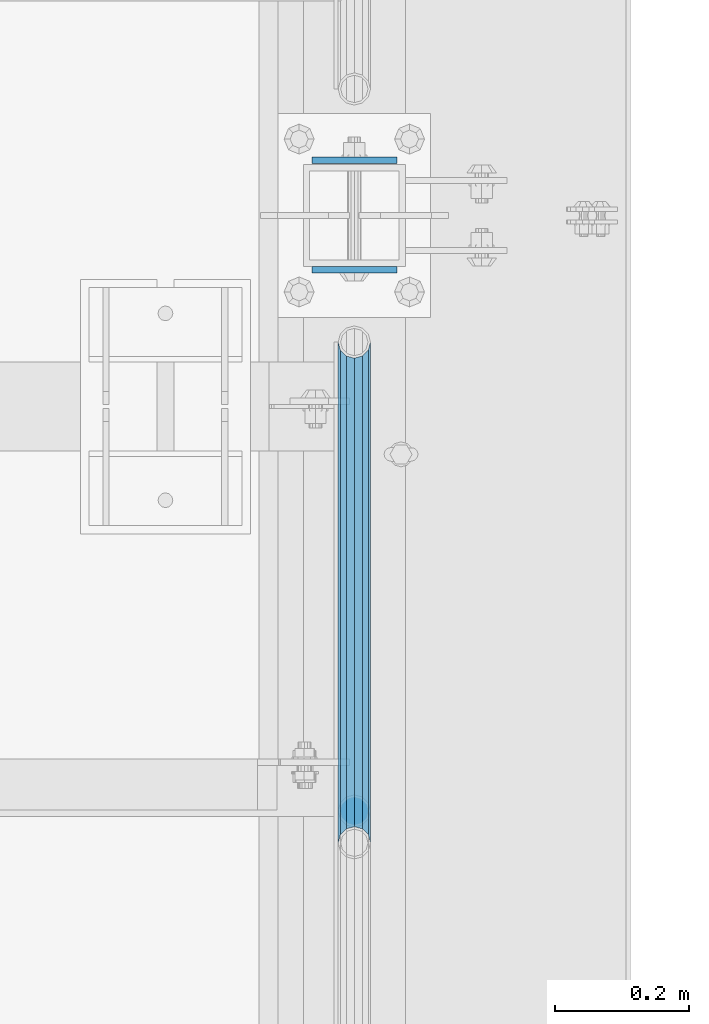
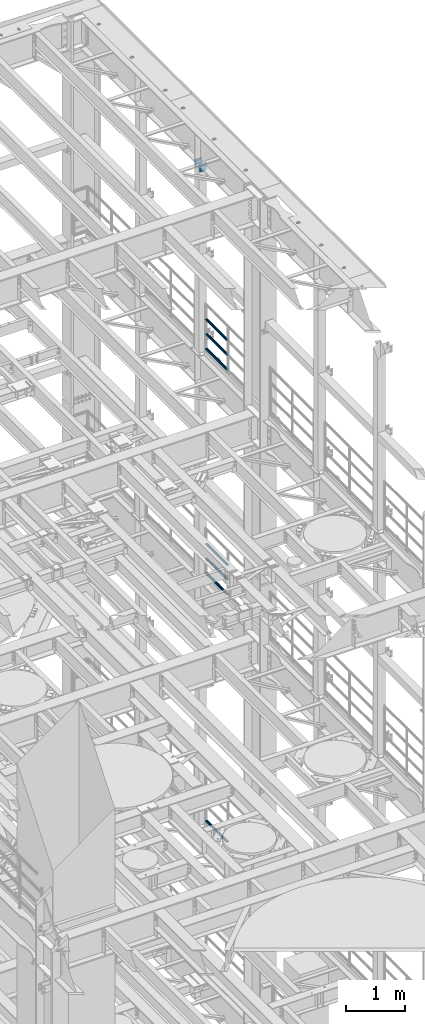
# One storey, part 1343 of 1876: 9 beams, 4 elements without a shape of their own.
"""IFC2X3 building model written with IfcOpenShell, lengths in millimetres."""

from ifc_helpers import new_model, si_unit, frame, origin_with_axes, place, context, subcontext, project, spatial, faceted_brep, material, type_object, element, aggregate, save


model = new_model("IFC2X3")

# Units and contexts
model_context = context("Model", 3, precision=1e-05, world=origin_with_axes())
body_context = subcontext(model_context, "Body", "Model", "MODEL_VIEW")
ifc_project = project(units=[si_unit("LENGTHUNIT", "METRE", prefix="MILLI"), si_unit("AREAUNIT", "SQUARE_METRE"), si_unit("VOLUMEUNIT", "CUBIC_METRE"), si_unit("MASSUNIT", "GRAM", prefix="KILO"), si_unit("TIMEUNIT", "SECOND"), si_unit("PLANEANGLEUNIT", "RADIAN"), si_unit("SOLIDANGLEUNIT", "STERADIAN"), si_unit("THERMODYNAMICTEMPERATUREUNIT", "DEGREE_CELSIUS"), si_unit("LUMINOUSINTENSITYUNIT", "LUMEN")], contexts=[model_context])

# Site, building, storey
site_placement = place(None, origin_with_axes())
site = spatial("IfcSite", under=ifc_project, at=site_placement, CompositionType="ELEMENT")
building_placement = place(site_placement, origin_with_axes())
building = spatial("IfcBuilding", under=site, at=building_placement, Name="Undefined", CompositionType="ELEMENT")
storey_placement = place(building_placement, origin_with_axes())
storey = spatial("IfcBuildingStorey", under=building, at=storey_placement, Name="Undefined", CompositionType="ELEMENT", Elevation=0.0)

# Assembly, beams
assembly_1_placement = place(storey_placement, origin_with_axes())
assembly_1 = element("IfcElementAssembly", 1, at=assembly_1_placement, inside=storey, Name="RAIL", AssemblyPlace="NOTDEFINED", PredefinedType="RIGID_FRAME")
ifc_material_1 = material()
beam_type_1 = type_object("IfcBeamType", Name="PIPE1-1/2SCH40", PredefinedType="NOTDEFINED")
beam_1_placement = place(assembly_1_placement, frame((7620.0, 9462.77, 18145.125), z_axis=(0.0, 0.0, 1.0), x_axis=(0.0, -1.0, 0.0)))
beam_1 = element("IfcBeam", 2, at=beam_1_placement, type_object=beam_type_1, material=ifc_material_1, Name="RAIL", ObjectType="PIPE1-1/2SCH40", context=body_context, shape_type="Brep", body=[
    faceted_brep([(728.085307006683, -12.0649999999996, 20.8971929933177), (728.085307006683, -12.0649999999996, 15.8661214311796), (727.591878568821, -10.2235000000001, 17.7076214311819), (724.852500000002, 0.0, 20.4470000000001), (724.852500000002, 0.0, 24.130000000001), (727.591878568821, 10.2235000000001, 17.7076214311819), (728.085307006683, 12.0649999999996, 15.8661214311796), (728.085307006683, 12.0649999999996, 20.8971929933177), (748.982500000002, 24.1300000000001, 0.0), (736.917500000002, 20.8971929933186, 12.0649999999987), (736.917500000002, 20.8971929933186, -12.0649999999987), (733.727928437864, 17.7076214311801, 10.2235000000001), (736.467307006683, 20.4470000000001, 0.0), (733.727928437864, 17.7076214311801, -10.2235000000001), (728.085307006683, 12.0649999999996, -15.8661214311796), (728.085307006683, 12.0649999999996, -20.8971929933177), (727.591878568821, 10.2235000000001, -17.7076214311819), (724.852500000002, 0.0, -20.4470000000001), (724.852500000002, 0.0, -24.130000000001), (728.085307006683, -12.0649999999996, -15.8661214311796), (728.085307006683, -12.0649999999996, -20.8971929933177), (727.591878568821, -10.2235000000001, -17.7076214311819), (748.982500000002, -24.1300000000001, 0.0), (736.917500000002, -20.8971929933186, -12.0649999999987), (736.917500000002, -20.8971929933186, 12.0649999999987), (733.727928437864, -17.7076214311801, -10.2235000000001), (736.467307006683, -20.4470000000001, 0.0), (733.727928437864, -17.7076214311801, 10.2235000000001), (12.0650000000064, -20.8971929933177, -12.0649999999987), (20.8971929933249, -12.0650000000005, -20.8971929933177), (0.0, 24.1299999999992, 0.0), (12.0650000000064, 20.8971929933177, -12.0649999999987), (12.0650000000064, 20.8971929933177, 12.0649999999987), (20.8971929933249, 12.0650000000005, 20.8971929933177), (24.1300000000064, 0.0, 24.130000000001), (20.8971929933249, 12.0650000000005, -20.8971929933177), (24.1300000000063, 0.0, -24.130000000001), (24.1300000000063, 0.0, -20.4470000000001), (20.8971929933249, -12.0650000000005, -15.8661214311796), (21.3906214311868, -10.2235000000001, -17.7076214311819), (21.3906214311868, 10.2235000000001, -17.7076214311819), (20.8971929933249, 12.0650000000005, -15.8661214311796), (15.2545715621445, 17.7076214311801, -10.2235000000001), (12.5151929933249, 20.4470000000001, 0.0), (15.2545715621445, 17.7076214311801, 10.2235000000001), (20.8971929933249, 12.0650000000005, 15.8661214311796), (21.3906214311868, 10.2235000000001, 17.7076214311819), (24.1300000000064, 0.0, 20.4470000000001), (21.3906214311868, -10.2235000000001, 17.7076214311819), (20.8971929933249, -12.0650000000005, 15.8661214311796), (20.8971929933249, -12.0650000000005, 20.8971929933177), (12.0650000000064, -20.8971929933177, 12.0649999999987), (0.0, -24.1299999999992, 0.0), (15.2545715621445, -17.7076214311801, 10.2235000000001), (12.5151929933249, -20.4470000000001, 0.0), (15.2545715621445, -17.7076214311801, -10.2235000000001)], [[[0, 1, 2, 3, 4]], [[4, 3, 5, 6, 7]], [[8, 9, 10]], [[7, 6, 11, 12, 13, 14, 15, 10, 9]], [[16, 17, 18, 15, 14]], [[19, 20, 18, 17, 21]], [[22, 23, 24]], [[24, 23, 20, 19, 25, 26, 27, 1, 0]], [[28, 29, 20, 23]], [[30, 31, 32]], [[33, 34, 4, 7]], [[32, 33, 7, 9]], [[30, 32, 9, 8]], [[31, 30, 8, 10]], [[35, 31, 10, 15]], [[36, 35, 15, 18]], [[29, 36, 18, 20]], [[37, 36, 29, 38, 39]], [[40, 41, 35, 36, 37]], [[32, 31, 35, 41, 42, 43, 44, 45, 33]], [[33, 45, 46, 47, 34]], [[34, 47, 48, 49, 50]], [[34, 50, 0, 4]], [[50, 51, 24, 0]], [[51, 52, 22, 24]], [[52, 28, 23, 22]], [[51, 28, 52]], [[50, 49, 53, 54, 55, 38, 29, 28, 51]], [[55, 54, 26, 25]], [[21, 39, 38, 55, 25, 19]], [[37, 39, 21, 17]], [[40, 37, 17, 16]], [[42, 41, 40, 16, 14, 13]], [[43, 42, 13, 12]], [[44, 43, 12, 11]], [[5, 46, 45, 44, 11, 6]], [[47, 46, 5, 3]], [[48, 47, 3, 2]], [[53, 49, 48, 2, 1, 27]], [[54, 53, 27, 26]]]),
])
beam_2_placement = place(assembly_1_placement, frame((7620.0, 8713.7875, 18449.925), z_axis=(0.0, 0.0, -1.0), x_axis=(0.0, 1.0, 0.0)))
beam_2 = element("IfcBeam", 3, at=beam_2_placement, type_object=beam_type_1, material=ifc_material_1, Name="RAIL", ObjectType="PIPE1-1/2SCH40", context=body_context, shape_type="Brep", body=[
    faceted_brep([(0.0, 24.1299999999992, 0.0), (12.0650000000064, 20.8971929933177, -12.0649999999987), (12.0650000000064, 20.8971929933177, 12.0649999999987), (12.0650000000064, -20.8971929933177, 12.0649999999987), (12.0650000000064, -20.8971929933177, -12.0649999999987), (0.0, -24.1299999999992, 0.0), (20.8971929933249, -12.0650000000005, 20.8971929933177), (20.8971929933249, -12.0650000000005, 15.8661214311796), (15.2545715621445, -17.7076214311801, 10.2235000000001), (12.5151929933249, -20.4470000000001, 0.0), (15.2545715621445, -17.7076214311801, -10.2235000000001), (20.8971929933249, -12.0650000000005, -15.8661214311796), (20.8971929933249, -12.0650000000005, -20.8971929933177), (24.1300000000063, 0.0, -20.4470000000001), (24.1300000000063, 0.0, -24.130000000001), (21.3906214311868, -10.2235000000001, -17.7076214311819), (21.3906214311868, 10.2235000000001, -17.7076214311819), (20.8971929933249, 12.0650000000005, -15.8661214311796), (20.8971929933249, 12.0650000000005, -20.8971929933177), (15.2545715621445, 17.7076214311801, -10.2235000000001), (12.5151929933249, 20.4470000000001, 0.0), (15.2545715621445, 17.7076214311801, 10.2235000000001), (20.8971929933249, 12.0650000000005, 15.8661214311796), (20.8971929933249, 12.0650000000005, 20.8971929933177), (21.3906214311868, 10.2235000000001, 17.7076214311819), (24.1300000000064, 0.0, 20.4470000000001), (24.1300000000064, 0.0, 24.130000000001), (21.3906214311868, -10.2235000000001, 17.7076214311819), (748.982500000002, 24.1300000000001, 0.0), (736.917500000002, 20.8971929933186, -12.0649999999987), (728.085307006683, 12.0649999999996, -20.8971929933177), (748.982500000002, -24.1300000000001, 0.0), (736.917500000002, -20.8971929933186, -12.0649999999987), (736.917500000002, -20.8971929933186, 12.0649999999987), (728.085307006683, -12.0649999999996, 20.8971929933177), (728.085307006683, -12.0649999999996, -20.8971929933177), (724.852500000002, 0.0, -24.130000000001), (727.591878568821, 10.2235000000001, -17.7076214311819), (724.852500000002, 0.0, -20.4470000000001), (728.085307006683, 12.0649999999996, -15.8661214311796), (728.085307006683, -12.0649999999996, -15.8661214311796), (727.591878568821, -10.2235000000001, -17.7076214311819), (733.727928437864, -17.7076214311801, -10.2235000000001), (736.467307006683, -20.4470000000001, 0.0), (733.727928437864, -17.7076214311801, 10.2235000000001), (728.085307006683, -12.0649999999996, 15.8661214311796), (727.591878568821, -10.2235000000001, 17.7076214311819), (724.852500000002, 0.0, 20.4470000000001), (724.852500000002, 0.0, 24.130000000001), (728.085307006683, 12.0649999999996, 20.8971929933177), (736.917500000002, 20.8971929933186, 12.0649999999987), (728.085307006683, 12.0649999999996, 15.8661214311796), (733.727928437864, 17.7076214311801, 10.2235000000001), (736.467307006683, 20.4470000000001, 0.0), (733.727928437864, 17.7076214311801, -10.2235000000001), (727.591878568821, 10.2235000000001, 17.7076214311819)], [[[0, 1, 2]], [[3, 4, 5]], [[6, 7, 8, 9, 10, 11, 12, 4, 3]], [[13, 14, 12, 11, 15]], [[16, 17, 18, 14, 13]], [[2, 1, 18, 17, 19, 20, 21, 22, 23]], [[23, 22, 24, 25, 26]], [[26, 25, 27, 7, 6]], [[1, 0, 28, 29]], [[18, 1, 29, 30]], [[31, 32, 33]], [[6, 3, 33, 34]], [[3, 5, 31, 33]], [[5, 4, 32, 31]], [[4, 12, 35, 32]], [[12, 14, 36, 35]], [[14, 18, 30, 36]], [[37, 38, 36, 30, 39]], [[40, 35, 36, 38, 41]], [[33, 32, 35, 40, 42, 43, 44, 45, 34]], [[34, 45, 46, 47, 48]], [[26, 6, 34, 48]], [[2, 23, 49, 50]], [[23, 26, 48, 49]], [[0, 2, 50, 28]], [[28, 50, 29]], [[49, 51, 52, 53, 54, 39, 30, 29, 50]], [[48, 47, 55, 51, 49]], [[25, 24, 55, 47]], [[55, 24, 22, 21, 52, 51]], [[21, 20, 53, 52]], [[20, 19, 54, 53]], [[19, 17, 16, 37, 39, 54]], [[16, 13, 38, 37]], [[13, 15, 41, 38]], [[41, 15, 11, 10, 42, 40]], [[10, 9, 43, 42]], [[9, 8, 44, 43]], [[8, 7, 27, 46, 45, 44]], [[27, 25, 47, 46]]]),
])
beam_3_placement = place(assembly_1_placement, frame((7620.0, 8713.7875, 18754.725), z_axis=(0.0, 0.0, -1.0), x_axis=(0.0, 1.0, 0.0)))
beam_3 = element("IfcBeam", 4, at=beam_3_placement, type_object=beam_type_1, material=ifc_material_1, Name="RAIL", ObjectType="PIPE1-1/2SCH40", context=body_context, shape_type="Brep", body=[
    faceted_brep([(0.0, 24.1299999999992, 0.0), (12.0650000000064, 20.8971929933177, -12.0649999999987), (12.0650000000064, 20.8971929933177, 12.0649999999987), (12.0650000000064, -20.8971929933177, 12.0649999999987), (12.0650000000064, -20.8971929933177, -12.0649999999987), (0.0, -24.1299999999992, 0.0), (20.8971929933249, -12.0650000000005, 20.8971929933177), (20.8971929933249, -12.0650000000005, 15.8661214311796), (15.2545715621445, -17.7076214311801, 10.2235000000001), (12.5151929933249, -20.4470000000001, 0.0), (15.2545715621445, -17.7076214311801, -10.2235000000001), (20.8971929933249, -12.0650000000005, -15.8661214311796), (20.8971929933249, -12.0650000000005, -20.8971929933177), (24.1300000000063, 0.0, -20.4470000000001), (24.1300000000063, 0.0, -24.130000000001), (21.3906214311868, -10.2235000000001, -17.7076214311819), (21.3906214311868, 10.2235000000001, -17.7076214311819), (20.8971929933249, 12.0650000000005, -15.8661214311796), (20.8971929933249, 12.0650000000005, -20.8971929933177), (15.2545715621445, 17.7076214311801, -10.2235000000001), (12.5151929933249, 20.4470000000001, 0.0), (15.2545715621445, 17.7076214311801, 10.2235000000001), (20.8971929933249, 12.0650000000005, 15.8661214311796), (20.8971929933249, 12.0650000000005, 20.8971929933177), (21.3906214311868, 10.2235000000001, 17.7076214311819), (24.1300000000064, 0.0, 20.4470000000001), (24.1300000000064, 0.0, 24.130000000001), (21.3906214311868, -10.2235000000001, 17.7076214311819), (748.982500000002, 24.1300000000001, 0.0), (736.917500000002, 20.8971929933186, -12.0649999999987), (728.085307006683, 12.0649999999996, -20.8971929933177), (748.982500000002, -24.1300000000001, 0.0), (736.917500000002, -20.8971929933186, -12.0649999999987), (736.917500000002, -20.8971929933186, 12.0649999999987), (728.085307006683, -12.0649999999996, 20.8971929933177), (728.085307006683, -12.0649999999996, -20.8971929933177), (724.852500000002, 0.0, -24.130000000001), (727.591878568821, 10.2235000000001, -17.7076214311819), (724.852500000002, 0.0, -20.4470000000001), (728.085307006683, 12.0649999999996, -15.8661214311796), (728.085307006683, -12.0649999999996, -15.8661214311796), (727.591878568821, -10.2235000000001, -17.7076214311819), (733.727928437864, -17.7076214311801, -10.2235000000001), (736.467307006683, -20.4470000000001, 0.0), (733.727928437864, -17.7076214311801, 10.2235000000001), (728.085307006683, -12.0649999999996, 15.8661214311796), (727.591878568821, -10.2235000000001, 17.7076214311819), (724.852500000002, 0.0, 20.4470000000001), (724.852500000002, 0.0, 24.130000000001), (728.085307006683, 12.0649999999996, 20.8971929933177), (736.917500000002, 20.8971929933186, 12.0649999999987), (728.085307006683, 12.0649999999996, 15.8661214311796), (733.727928437864, 17.7076214311801, 10.2235000000001), (736.467307006683, 20.4470000000001, 0.0), (733.727928437864, 17.7076214311801, -10.2235000000001), (727.591878568821, 10.2235000000001, 17.7076214311819)], [[[0, 1, 2]], [[3, 4, 5]], [[6, 7, 8, 9, 10, 11, 12, 4, 3]], [[13, 14, 12, 11, 15]], [[16, 17, 18, 14, 13]], [[2, 1, 18, 17, 19, 20, 21, 22, 23]], [[23, 22, 24, 25, 26]], [[26, 25, 27, 7, 6]], [[1, 0, 28, 29]], [[18, 1, 29, 30]], [[31, 32, 33]], [[6, 3, 33, 34]], [[3, 5, 31, 33]], [[5, 4, 32, 31]], [[4, 12, 35, 32]], [[12, 14, 36, 35]], [[14, 18, 30, 36]], [[37, 38, 36, 30, 39]], [[40, 35, 36, 38, 41]], [[33, 32, 35, 40, 42, 43, 44, 45, 34]], [[34, 45, 46, 47, 48]], [[26, 6, 34, 48]], [[2, 23, 49, 50]], [[23, 26, 48, 49]], [[0, 2, 50, 28]], [[28, 50, 29]], [[49, 51, 52, 53, 54, 39, 30, 29, 50]], [[48, 47, 55, 51, 49]], [[25, 24, 55, 47]], [[55, 24, 22, 21, 52, 51]], [[21, 20, 53, 52]], [[20, 19, 54, 53]], [[19, 17, 16, 37, 39, 54]], [[16, 13, 38, 37]], [[13, 15, 41, 38]], [[41, 15, 11, 10, 42, 40]], [[10, 9, 43, 42]], [[9, 8, 44, 43]], [[8, 7, 27, 46, 45, 44]], [[27, 25, 47, 46]]]),
])
aggregate(assembly_1, [beam_1, beam_2, beam_3])

assembly_2_placement = place(storey_placement, origin_with_axes())
assembly_2 = element("IfcElementAssembly", 5, at=assembly_2_placement, inside=storey, Name="RAIL", AssemblyPlace="NOTDEFINED", PredefinedType="RIGID_FRAME")
beam_4_placement = place(assembly_2_placement, frame((7620.0, 9462.77, 13471.525), z_axis=(0.0, 0.0, 1.0), x_axis=(0.0, -1.0, 0.0)))
beam_4 = element("IfcBeam", 6, at=beam_4_placement, type_object=beam_type_1, material=ifc_material_1, Name="RAIL", ObjectType="PIPE1-1/2SCH40", context=body_context, shape_type="Brep", body=[
    faceted_brep([(728.085307006683, -12.0649999999996, 20.8971929933177), (728.085307006683, -12.0649999999996, 15.8661214311796), (727.591878568821, -10.2235000000001, 17.7076214311819), (724.852500000002, 0.0, 20.4470000000001), (724.852500000002, 0.0, 24.130000000001), (727.591878568821, 10.2235000000001, 17.7076214311819), (728.085307006683, 12.0649999999996, 15.8661214311796), (728.085307006683, 12.0649999999996, 20.8971929933177), (748.982500000002, 24.1300000000001, 0.0), (736.917500000002, 20.8971929933186, 12.0649999999987), (736.917500000002, 20.8971929933186, -12.0649999999987), (733.727928437864, 17.7076214311801, 10.2235000000001), (736.467307006683, 20.4470000000001, 0.0), (733.727928437864, 17.7076214311801, -10.2235000000001), (728.085307006683, 12.0649999999996, -15.8661214311796), (728.085307006683, 12.0649999999996, -20.8971929933177), (727.591878568821, 10.2235000000001, -17.7076214311819), (724.852500000002, 0.0, -20.4470000000001), (724.852500000002, 0.0, -24.130000000001), (728.085307006683, -12.0649999999996, -15.8661214311796), (728.085307006683, -12.0649999999996, -20.8971929933177), (727.591878568821, -10.2235000000001, -17.7076214311819), (748.982500000002, -24.1300000000001, 0.0), (736.917500000002, -20.8971929933186, -12.0649999999987), (736.917500000002, -20.8971929933186, 12.0649999999987), (733.727928437864, -17.7076214311801, -10.2235000000001), (736.467307006683, -20.4470000000001, 0.0), (733.727928437864, -17.7076214311801, 10.2235000000001), (12.0650000000064, -20.8971929933177, -12.0649999999987), (20.8971929933249, -12.0650000000005, -20.8971929933177), (0.0, 24.1299999999992, 0.0), (12.0650000000064, 20.8971929933177, -12.0649999999987), (12.0650000000064, 20.8971929933177, 12.0649999999987), (20.8971929933249, 12.0650000000005, 20.8971929933177), (24.1300000000064, 0.0, 24.130000000001), (20.8971929933249, 12.0650000000005, -20.8971929933177), (24.1300000000063, 0.0, -24.130000000001), (24.1300000000063, 0.0, -20.4470000000001), (20.8971929933249, -12.0650000000005, -15.8661214311796), (21.3906214311868, -10.2235000000001, -17.7076214311819), (21.3906214311868, 10.2235000000001, -17.7076214311819), (20.8971929933249, 12.0650000000005, -15.8661214311796), (15.2545715621445, 17.7076214311801, -10.2235000000001), (12.5151929933249, 20.4470000000001, 0.0), (15.2545715621445, 17.7076214311801, 10.2235000000001), (20.8971929933249, 12.0650000000005, 15.8661214311796), (21.3906214311868, 10.2235000000001, 17.7076214311819), (24.1300000000064, 0.0, 20.4470000000001), (21.3906214311868, -10.2235000000001, 17.7076214311819), (20.8971929933249, -12.0650000000005, 15.8661214311796), (20.8971929933249, -12.0650000000005, 20.8971929933177), (12.0650000000064, -20.8971929933177, 12.0649999999987), (0.0, -24.1299999999992, 0.0), (15.2545715621445, -17.7076214311801, 10.2235000000001), (12.5151929933249, -20.4470000000001, 0.0), (15.2545715621445, -17.7076214311801, -10.2235000000001)], [[[0, 1, 2, 3, 4]], [[4, 3, 5, 6, 7]], [[8, 9, 10]], [[7, 6, 11, 12, 13, 14, 15, 10, 9]], [[16, 17, 18, 15, 14]], [[19, 20, 18, 17, 21]], [[22, 23, 24]], [[24, 23, 20, 19, 25, 26, 27, 1, 0]], [[28, 29, 20, 23]], [[30, 31, 32]], [[33, 34, 4, 7]], [[32, 33, 7, 9]], [[30, 32, 9, 8]], [[31, 30, 8, 10]], [[35, 31, 10, 15]], [[36, 35, 15, 18]], [[29, 36, 18, 20]], [[37, 36, 29, 38, 39]], [[40, 41, 35, 36, 37]], [[32, 31, 35, 41, 42, 43, 44, 45, 33]], [[33, 45, 46, 47, 34]], [[34, 47, 48, 49, 50]], [[34, 50, 0, 4]], [[50, 51, 24, 0]], [[51, 52, 22, 24]], [[52, 28, 23, 22]], [[51, 28, 52]], [[50, 49, 53, 54, 55, 38, 29, 28, 51]], [[55, 54, 26, 25]], [[21, 39, 38, 55, 25, 19]], [[37, 39, 21, 17]], [[40, 37, 17, 16]], [[42, 41, 40, 16, 14, 13]], [[43, 42, 13, 12]], [[44, 43, 12, 11]], [[5, 46, 45, 44, 11, 6]], [[47, 46, 5, 3]], [[48, 47, 3, 2]], [[53, 49, 48, 2, 1, 27]], [[54, 53, 27, 26]]]),
])
beam_5_placement = place(assembly_2_placement, frame((7620.0, 8713.7875, 13776.325), z_axis=(0.0, 0.0, -1.0), x_axis=(0.0, 1.0, 0.0)))
beam_5 = element("IfcBeam", 7, at=beam_5_placement, type_object=beam_type_1, material=ifc_material_1, Name="RAIL", ObjectType="PIPE1-1/2SCH40", context=body_context, shape_type="Brep", body=[
    faceted_brep([(0.0, 24.1299999999992, 0.0), (12.0650000000064, 20.8971929933177, -12.0649999999987), (12.0650000000064, 20.8971929933177, 12.0649999999987), (12.0650000000064, -20.8971929933177, 12.0649999999987), (12.0650000000064, -20.8971929933177, -12.0649999999987), (0.0, -24.1299999999992, 0.0), (20.8971929933249, -12.0650000000005, 20.8971929933177), (20.8971929933249, -12.0650000000005, 15.8661214311796), (15.2545715621445, -17.7076214311801, 10.2235000000001), (12.5151929933249, -20.4470000000001, 0.0), (15.2545715621445, -17.7076214311801, -10.2235000000001), (20.8971929933249, -12.0650000000005, -15.8661214311796), (20.8971929933249, -12.0650000000005, -20.8971929933177), (24.1300000000063, 0.0, -20.4470000000001), (24.1300000000063, 0.0, -24.130000000001), (21.3906214311868, -10.2235000000001, -17.7076214311819), (21.3906214311868, 10.2235000000001, -17.7076214311819), (20.8971929933249, 12.0650000000005, -15.8661214311796), (20.8971929933249, 12.0650000000005, -20.8971929933177), (15.2545715621445, 17.7076214311801, -10.2235000000001), (12.5151929933249, 20.4470000000001, 0.0), (15.2545715621445, 17.7076214311801, 10.2235000000001), (20.8971929933249, 12.0650000000005, 15.8661214311796), (20.8971929933249, 12.0650000000005, 20.8971929933177), (21.3906214311868, 10.2235000000001, 17.7076214311819), (24.1300000000064, 0.0, 20.4470000000001), (24.1300000000064, 0.0, 24.130000000001), (21.3906214311868, -10.2235000000001, 17.7076214311819), (748.982500000002, 24.1300000000001, 0.0), (736.917500000002, 20.8971929933186, -12.0649999999987), (728.085307006683, 12.0649999999996, -20.8971929933177), (748.982500000002, -24.1300000000001, 0.0), (736.917500000002, -20.8971929933186, -12.0649999999987), (736.917500000002, -20.8971929933186, 12.0649999999987), (728.085307006683, -12.0649999999996, 20.8971929933177), (728.085307006683, -12.0649999999996, -20.8971929933177), (724.852500000002, 0.0, -24.130000000001), (727.591878568821, 10.2235000000001, -17.7076214311819), (724.852500000002, 0.0, -20.4470000000001), (728.085307006683, 12.0649999999996, -15.8661214311796), (728.085307006683, -12.0649999999996, -15.8661214311796), (727.591878568821, -10.2235000000001, -17.7076214311819), (733.727928437864, -17.7076214311801, -10.2235000000001), (736.467307006683, -20.4470000000001, 0.0), (733.727928437864, -17.7076214311801, 10.2235000000001), (728.085307006683, -12.0649999999996, 15.8661214311796), (727.591878568821, -10.2235000000001, 17.7076214311819), (724.852500000002, 0.0, 20.4470000000001), (724.852500000002, 0.0, 24.130000000001), (728.085307006683, 12.0649999999996, 20.8971929933177), (736.917500000002, 20.8971929933186, 12.0649999999987), (728.085307006683, 12.0649999999996, 15.8661214311796), (733.727928437864, 17.7076214311801, 10.2235000000001), (736.467307006683, 20.4470000000001, 0.0), (733.727928437864, 17.7076214311801, -10.2235000000001), (727.591878568821, 10.2235000000001, 17.7076214311819)], [[[0, 1, 2]], [[3, 4, 5]], [[6, 7, 8, 9, 10, 11, 12, 4, 3]], [[13, 14, 12, 11, 15]], [[16, 17, 18, 14, 13]], [[2, 1, 18, 17, 19, 20, 21, 22, 23]], [[23, 22, 24, 25, 26]], [[26, 25, 27, 7, 6]], [[1, 0, 28, 29]], [[18, 1, 29, 30]], [[31, 32, 33]], [[6, 3, 33, 34]], [[3, 5, 31, 33]], [[5, 4, 32, 31]], [[4, 12, 35, 32]], [[12, 14, 36, 35]], [[14, 18, 30, 36]], [[37, 38, 36, 30, 39]], [[40, 35, 36, 38, 41]], [[33, 32, 35, 40, 42, 43, 44, 45, 34]], [[34, 45, 46, 47, 48]], [[26, 6, 34, 48]], [[2, 23, 49, 50]], [[23, 26, 48, 49]], [[0, 2, 50, 28]], [[28, 50, 29]], [[49, 51, 52, 53, 54, 39, 30, 29, 50]], [[48, 47, 55, 51, 49]], [[25, 24, 55, 47]], [[55, 24, 22, 21, 52, 51]], [[21, 20, 53, 52]], [[20, 19, 54, 53]], [[19, 17, 16, 37, 39, 54]], [[16, 13, 38, 37]], [[13, 15, 41, 38]], [[41, 15, 11, 10, 42, 40]], [[10, 9, 43, 42]], [[9, 8, 44, 43]], [[8, 7, 27, 46, 45, 44]], [[27, 25, 47, 46]]]),
])
beam_6_placement = place(assembly_2_placement, frame((7620.0, 8713.7875, 14081.125), z_axis=(0.0, 0.0, -1.0), x_axis=(0.0, 1.0, 0.0)))
beam_6 = element("IfcBeam", 8, at=beam_6_placement, type_object=beam_type_1, material=ifc_material_1, Name="RAIL", ObjectType="PIPE1-1/2SCH40", context=body_context, shape_type="Brep", body=[
    faceted_brep([(0.0, 24.1299999999992, 0.0), (12.0650000000064, 20.8971929933177, -12.0649999999987), (12.0650000000064, 20.8971929933177, 12.0649999999987), (12.0650000000064, -20.8971929933177, 12.0649999999987), (12.0650000000064, -20.8971929933177, -12.0649999999987), (0.0, -24.1299999999992, 0.0), (20.8971929933249, -12.0650000000005, 20.8971929933177), (20.8971929933249, -12.0650000000005, 15.8661214311796), (15.2545715621445, -17.7076214311801, 10.2235000000001), (12.5151929933249, -20.4470000000001, 0.0), (15.2545715621445, -17.7076214311801, -10.2235000000001), (20.8971929933249, -12.0650000000005, -15.8661214311796), (20.8971929933249, -12.0650000000005, -20.8971929933177), (24.1300000000063, 0.0, -20.4470000000001), (24.1300000000063, 0.0, -24.130000000001), (21.3906214311868, -10.2235000000001, -17.7076214311819), (21.3906214311868, 10.2235000000001, -17.7076214311819), (20.8971929933249, 12.0650000000005, -15.8661214311796), (20.8971929933249, 12.0650000000005, -20.8971929933177), (15.2545715621445, 17.7076214311801, -10.2235000000001), (12.5151929933249, 20.4470000000001, 0.0), (15.2545715621445, 17.7076214311801, 10.2235000000001), (20.8971929933249, 12.0650000000005, 15.8661214311796), (20.8971929933249, 12.0650000000005, 20.8971929933177), (21.3906214311868, 10.2235000000001, 17.7076214311819), (24.1300000000064, 0.0, 20.4470000000001), (24.1300000000064, 0.0, 24.130000000001), (21.3906214311868, -10.2235000000001, 17.7076214311819), (748.982500000002, 24.1300000000001, 0.0), (736.917500000002, 20.8971929933186, -12.0649999999987), (728.085307006683, 12.0649999999996, -20.8971929933177), (748.982500000002, -24.1300000000001, 0.0), (736.917500000002, -20.8971929933186, -12.0649999999987), (736.917500000002, -20.8971929933186, 12.0649999999987), (728.085307006683, -12.0649999999996, 20.8971929933177), (728.085307006683, -12.0649999999996, -20.8971929933177), (724.852500000002, 0.0, -24.130000000001), (727.591878568821, 10.2235000000001, -17.7076214311819), (724.852500000002, 0.0, -20.4470000000001), (728.085307006683, 12.0649999999996, -15.8661214311796), (728.085307006683, -12.0649999999996, -15.8661214311796), (727.591878568821, -10.2235000000001, -17.7076214311819), (733.727928437864, -17.7076214311801, -10.2235000000001), (736.467307006683, -20.4470000000001, 0.0), (733.727928437864, -17.7076214311801, 10.2235000000001), (728.085307006683, -12.0649999999996, 15.8661214311796), (727.591878568821, -10.2235000000001, 17.7076214311819), (724.852500000002, 0.0, 20.4470000000001), (724.852500000002, 0.0, 24.130000000001), (728.085307006683, 12.0649999999996, 20.8971929933177), (736.917500000002, 20.8971929933186, 12.0649999999987), (728.085307006683, 12.0649999999996, 15.8661214311796), (733.727928437864, 17.7076214311801, 10.2235000000001), (736.467307006683, 20.4470000000001, 0.0), (733.727928437864, 17.7076214311801, -10.2235000000001), (727.591878568821, 10.2235000000001, 17.7076214311819)], [[[0, 1, 2]], [[3, 4, 5]], [[6, 7, 8, 9, 10, 11, 12, 4, 3]], [[13, 14, 12, 11, 15]], [[16, 17, 18, 14, 13]], [[2, 1, 18, 17, 19, 20, 21, 22, 23]], [[23, 22, 24, 25, 26]], [[26, 25, 27, 7, 6]], [[1, 0, 28, 29]], [[18, 1, 29, 30]], [[31, 32, 33]], [[6, 3, 33, 34]], [[3, 5, 31, 33]], [[5, 4, 32, 31]], [[4, 12, 35, 32]], [[12, 14, 36, 35]], [[14, 18, 30, 36]], [[37, 38, 36, 30, 39]], [[40, 35, 36, 38, 41]], [[33, 32, 35, 40, 42, 43, 44, 45, 34]], [[34, 45, 46, 47, 48]], [[26, 6, 34, 48]], [[2, 23, 49, 50]], [[23, 26, 48, 49]], [[0, 2, 50, 28]], [[28, 50, 29]], [[49, 51, 52, 53, 54, 39, 30, 29, 50]], [[48, 47, 55, 51, 49]], [[25, 24, 55, 47]], [[55, 24, 22, 21, 52, 51]], [[21, 20, 53, 52]], [[20, 19, 54, 53]], [[19, 17, 16, 37, 39, 54]], [[16, 13, 38, 37]], [[13, 15, 41, 38]], [[41, 15, 11, 10, 42, 40]], [[10, 9, 43, 42]], [[9, 8, 44, 43]], [[8, 7, 27, 46, 45, 44]], [[27, 25, 47, 46]]]),
])
aggregate(assembly_2, [beam_4, beam_5, beam_6])

# Assembly, beam
assembly_3_placement = place(storey_placement, origin_with_axes())
assembly_3 = element("IfcElementAssembly", 9, at=assembly_3_placement, inside=storey, Name="RAIL", AssemblyPlace="NOTDEFINED", PredefinedType="RIGID_FRAME")
beam_7_placement = place(assembly_3_placement, frame((7620.0, 9462.77, 8315.325), z_axis=(0.0, 0.0, 1.0), x_axis=(0.0, -1.0, 0.0)))
beam_7 = element("IfcBeam", 10, at=beam_7_placement, type_object=beam_type_1, material=ifc_material_1, Name="RAIL", ObjectType="PIPE1-1/2SCH40", context=body_context, shape_type="Brep", body=[
    faceted_brep([(728.085307006683, -12.0649999999996, 20.8971929933177), (728.085307006683, -12.0649999999996, 15.8661214311796), (727.591878568821, -10.2235000000001, 17.7076214311819), (724.852500000002, 0.0, 20.4470000000001), (724.852500000002, 0.0, 24.130000000001), (727.591878568821, 10.2235000000001, 17.7076214311819), (728.085307006683, 12.0649999999996, 15.8661214311796), (728.085307006683, 12.0649999999996, 20.8971929933177), (748.982500000002, 24.1300000000001, 0.0), (736.917500000002, 20.8971929933186, 12.0649999999987), (736.917500000002, 20.8971929933186, -12.0649999999987), (733.727928437864, 17.7076214311801, 10.2235000000001), (736.467307006683, 20.4470000000001, 0.0), (733.727928437864, 17.7076214311801, -10.2235000000001), (728.085307006683, 12.0649999999996, -15.8661214311796), (728.085307006683, 12.0649999999996, -20.8971929933177), (727.591878568821, 10.2235000000001, -17.7076214311819), (724.852500000002, 0.0, -20.4470000000001), (724.852500000002, 0.0, -24.130000000001), (728.085307006683, -12.0649999999996, -15.8661214311796), (728.085307006683, -12.0649999999996, -20.8971929933177), (727.591878568821, -10.2235000000001, -17.7076214311819), (748.982500000002, -24.1300000000001, 0.0), (736.917500000002, -20.8971929933186, -12.0649999999987), (736.917500000002, -20.8971929933186, 12.0649999999987), (733.727928437864, -17.7076214311801, -10.2235000000001), (736.467307006683, -20.4470000000001, 0.0), (733.727928437864, -17.7076214311801, 10.2235000000001), (12.0650000000064, -20.8971929933177, -12.0649999999987), (20.8971929933249, -12.0650000000005, -20.8971929933177), (0.0, 24.1299999999992, 0.0), (12.0650000000064, 20.8971929933177, -12.0649999999987), (12.0650000000064, 20.8971929933177, 12.0649999999987), (20.8971929933249, 12.0650000000005, 20.8971929933177), (24.1300000000064, 0.0, 24.130000000001), (20.8971929933249, 12.0650000000005, -20.8971929933177), (24.1300000000063, 0.0, -24.130000000001), (24.1300000000063, 0.0, -20.4470000000001), (20.8971929933249, -12.0650000000005, -15.8661214311796), (21.3906214311868, -10.2235000000001, -17.7076214311819), (21.3906214311868, 10.2235000000001, -17.7076214311819), (20.8971929933249, 12.0650000000005, -15.8661214311796), (15.2545715621445, 17.7076214311801, -10.2235000000001), (12.5151929933249, 20.4470000000001, 0.0), (15.2545715621445, 17.7076214311801, 10.2235000000001), (20.8971929933249, 12.0650000000005, 15.8661214311796), (21.3906214311868, 10.2235000000001, 17.7076214311819), (24.1300000000064, 0.0, 20.4470000000001), (21.3906214311868, -10.2235000000001, 17.7076214311819), (20.8971929933249, -12.0650000000005, 15.8661214311796), (20.8971929933249, -12.0650000000005, 20.8971929933177), (12.0650000000064, -20.8971929933177, 12.0649999999987), (0.0, -24.1299999999992, 0.0), (15.2545715621445, -17.7076214311801, 10.2235000000001), (12.5151929933249, -20.4470000000001, 0.0), (15.2545715621445, -17.7076214311801, -10.2235000000001)], [[[0, 1, 2, 3, 4]], [[4, 3, 5, 6, 7]], [[8, 9, 10]], [[7, 6, 11, 12, 13, 14, 15, 10, 9]], [[16, 17, 18, 15, 14]], [[19, 20, 18, 17, 21]], [[22, 23, 24]], [[24, 23, 20, 19, 25, 26, 27, 1, 0]], [[28, 29, 20, 23]], [[30, 31, 32]], [[33, 34, 4, 7]], [[32, 33, 7, 9]], [[30, 32, 9, 8]], [[31, 30, 8, 10]], [[35, 31, 10, 15]], [[36, 35, 15, 18]], [[29, 36, 18, 20]], [[37, 36, 29, 38, 39]], [[40, 41, 35, 36, 37]], [[32, 31, 35, 41, 42, 43, 44, 45, 33]], [[33, 45, 46, 47, 34]], [[34, 47, 48, 49, 50]], [[34, 50, 0, 4]], [[50, 51, 24, 0]], [[51, 52, 22, 24]], [[52, 28, 23, 22]], [[51, 28, 52]], [[50, 49, 53, 54, 55, 38, 29, 28, 51]], [[55, 54, 26, 25]], [[21, 39, 38, 55, 25, 19]], [[37, 39, 21, 17]], [[40, 37, 17, 16]], [[42, 41, 40, 16, 14, 13]], [[43, 42, 13, 12]], [[44, 43, 12, 11]], [[5, 46, 45, 44, 11, 6]], [[47, 46, 5, 3]], [[48, 47, 3, 2]], [[53, 49, 48, 2, 1, 27]], [[54, 53, 27, 26]]]),
])
aggregate(assembly_3, [beam_7])

# Assembly, beams
assembly_4_placement = place(storey_placement, origin_with_axes())
assembly_4 = element("IfcElementAssembly", 11, at=assembly_4_placement, inside=storey, Name="BEAM", AssemblyPlace="NOTDEFINED", PredefinedType="RIGID_FRAME")
ifc_material_2 = material(Name="STEEL/A36")
beam_type_2 = type_object("IfcBeamType", PredefinedType="NOTDEFINED")
beam_8_placement = place(assembly_4_placement, frame((7556.5, 9734.55, 21850.35), z_axis=(0.0, 0.0, -1.0), x_axis=(1.0, 0.0, 0.0)))
beam_8 = element("IfcBeam", 12, at=beam_8_placement, type_object=beam_type_2, material=ifc_material_2, Name="PLATE", context=body_context, shape_type="Brep", body=[
    faceted_brep([(0.0, 4.76249999999982, -82.5499999999993), (0.0, 4.76249999999982, 82.5499999999993), (127.0, 4.76249999999982, 82.5499999999993), (127.0, 4.76249999999982, -82.5499999999993), (0.0, -4.76249999999982, 82.5499999999993), (127.0, -4.76249999999982, 82.5499999999993), (0.0, -4.76249999999982, -82.5499999999993), (127.0, -4.76249999999982, -82.5499999999993)], [[[0, 1, 2, 3]], [[1, 4, 5, 2]], [[4, 6, 7, 5]], [[6, 0, 3, 7]], [[5, 7, 3, 2]], [[6, 4, 1, 0]]]),
])
beam_9_placement = place(assembly_4_placement, frame((7556.5, 9571.0375, 21850.35), z_axis=(0.0, 0.0, -1.0), x_axis=(1.0, 0.0, 0.0)))
beam_9 = element("IfcBeam", 13, at=beam_9_placement, type_object=beam_type_2, material=ifc_material_2, Name="PLATE", context=body_context, shape_type="Brep", body=[
    faceted_brep([(0.0, 4.76249999999982, -82.5499999999993), (0.0, 4.76249999999982, 82.5499999999993), (127.0, 4.76249999999982, 82.5499999999993), (127.0, 4.76249999999982, -82.5499999999993), (0.0, -4.76249999999982, 82.5499999999993), (127.0, -4.76249999999982, 82.5499999999993), (0.0, -4.76249999999982, -82.5499999999993), (127.0, -4.76249999999982, -82.5499999999993)], [[[0, 1, 2, 3]], [[1, 4, 5, 2]], [[4, 6, 7, 5]], [[6, 0, 3, 7]], [[5, 7, 3, 2]], [[6, 4, 1, 0]]]),
])
aggregate(assembly_4, [beam_8, beam_9])

save(model, "model.ifc")
